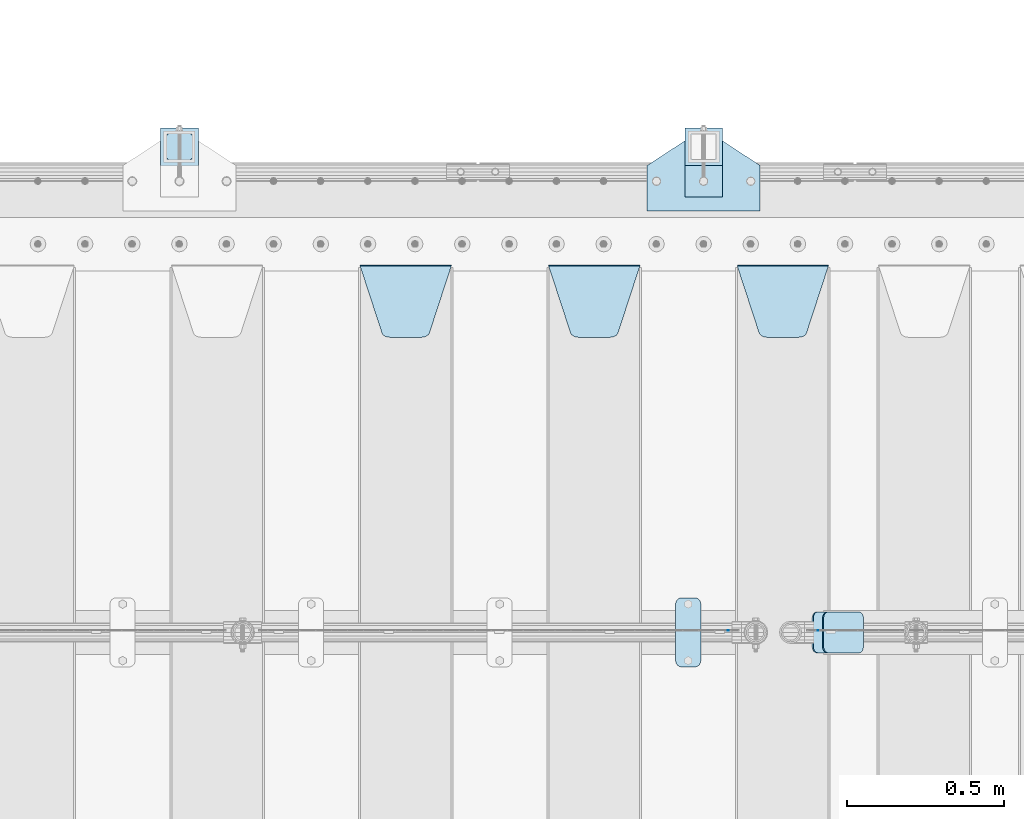
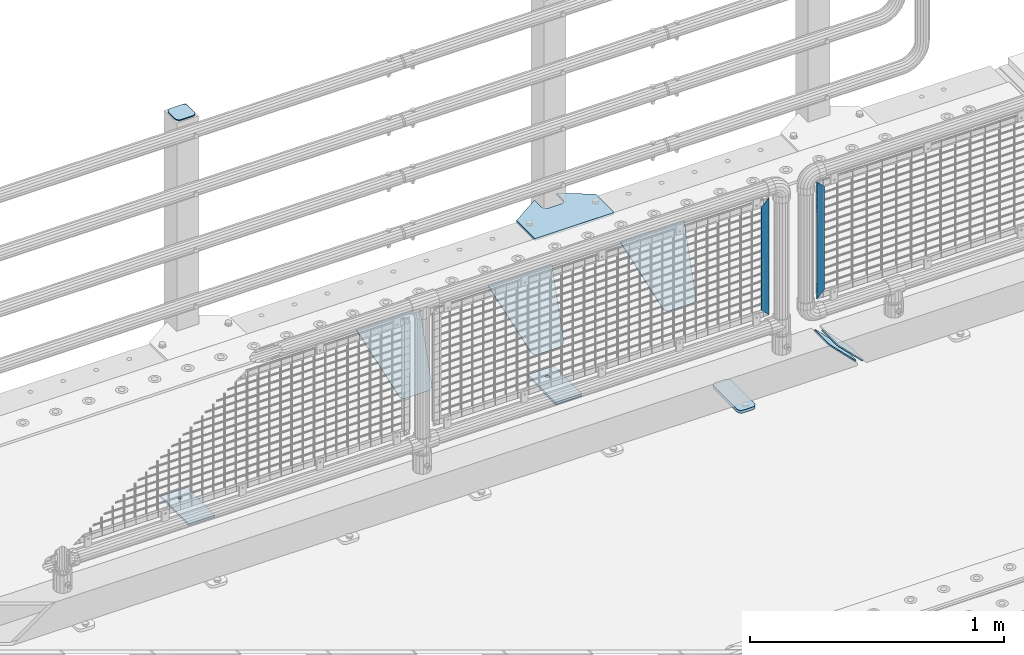
# One storey, part 250 of 270: 13 plates.
"""IFC2X3 building model written with IfcOpenShell, lengths in millimetres."""

import ifcopenshell
import ifcopenshell.guid

model = None  # the IFC model being written
_history = None  # IfcOwnerHistory: only IFC2X3 demands one
_inside = {}  # id of a spatial element -> (the spatial element, [elements in it])
_under = {}  # id of a project, library or spatial element -> (it, [spatial elements below it])
_declared = {}  # id of a project -> (the project, [libraries it declares])
_typed = {}  # id of a type object -> (the type object, [elements of that type])
_made_of = {}  # id of a material, layer set ... -> (it, [elements and type objects made of it])


def new_model(schema):
    """Start an empty IFC model of exactly this schema.

    Asked for "IFC4X3", IfcOpenShell would pick the latest addendum, in which some entities
    have other attributes; the version numbers below select the first issue.
    IFC2X3 requires an IfcOwnerHistory on every rooted entity: one is made here for all.
    """
    global model, _history
    if schema == "IFC4X3":
        model = ifcopenshell.file(schema_version=(4, 3, 0, 0))
    else:
        model = ifcopenshell.file(schema=schema)
    _inside.clear()
    _under.clear()
    _declared.clear()
    _typed.clear()
    _made_of.clear()
    _history = None
    if model.schema == "IFC2X3":
        org = make("IfcOrganization", Name="unknown")
        user = make(
            "IfcPersonAndOrganization",
            ThePerson=make("IfcPerson", FamilyName="unknown"),
            TheOrganization=org,
        )
        app = make(
            "IfcApplication",
            ApplicationDeveloper=org,
            Version="unknown",
            ApplicationFullName="unknown",
            ApplicationIdentifier="unknown",
        )
        _history = make(
            "IfcOwnerHistory",
            OwningUser=user,
            OwningApplication=app,
            ChangeAction="ADDED",
            CreationDate=0,
        )
    return model


def make(cls, **values):
    """One entity of the class cls with the attributes given. An attribute that is None is left unset."""
    return model.create_entity(
        cls, **{name: value for name, value in values.items() if value is not None}
    )


def rooted(cls, **values):
    """An entity with a GlobalId (a new one), such as an element, a storey or a relation."""
    return make(cls, GlobalId=ifcopenshell.guid.new(), OwnerHistory=_history, **values)


def si_unit(unit_type, name, prefix=None):
    """IfcSIUnit, for example si_unit("LENGTHUNIT", "METRE", prefix="MILLI")."""
    return make("IfcSIUnit", UnitType=unit_type, Prefix=prefix, Name=name)


def assignment(units):
    """IfcUnitAssignment: the units of a project."""
    return None if units is None else make("IfcUnitAssignment", Units=units)


def point(xyz):
    """IfcCartesianPoint."""
    return None if xyz is None else make("IfcCartesianPoint", Coordinates=xyz)


def direction(xyz):
    """IfcDirection."""
    return None if xyz is None else make("IfcDirection", DirectionRatios=xyz)


def frame(location, z_axis=None, x_axis=None):
    """IfcAxis2Placement3D, a coordinate frame: its origin and axes. An axis left out is left unset."""
    return make(
        "IfcAxis2Placement3D",
        Location=point(location),
        Axis=direction(z_axis),
        RefDirection=direction(x_axis),
    )


def origin_with_axes():
    """The frame at (0, 0, 0) with the z axis (0, 0, 1) and the x axis (1, 0, 0) written out."""
    return frame((0.0, 0.0, 0.0), z_axis=(0.0, 0.0, 1.0), x_axis=(1.0, 0.0, 0.0))


def place(relative_to, where):
    """IfcLocalPlacement: puts the frame where relative to a parent placement (None: the world)."""
    return make(
        "IfcLocalPlacement", PlacementRelTo=relative_to, RelativePlacement=where
    )


def context(
    kind, dimensions, precision=None, world=None, true_north=None, identifier=None
):
    """IfcGeometricRepresentationContext, for example the 3D "Model" context."""
    return make(
        "IfcGeometricRepresentationContext",
        ContextIdentifier=identifier,
        ContextType=kind,
        CoordinateSpaceDimension=dimensions,
        Precision=precision,
        WorldCoordinateSystem=world,
        TrueNorth=true_north,
    )


def subcontext(parent, identifier, kind, view, scale=None):
    """IfcGeometricRepresentationSubContext, for example "Body" below "Model"."""
    return make(
        "IfcGeometricRepresentationSubContext",
        ContextIdentifier=identifier,
        ContextType=kind,
        ParentContext=parent,
        TargetScale=scale,
        TargetView=view,
    )


def project(units=None, contexts=None):
    """IfcProject with its units and contexts."""
    return rooted(
        "IfcProject",
        Name="project",
        RepresentationContexts=contexts,
        UnitsInContext=assignment(units),
    )


def spatial(cls, under=None, at=None, **own):
    """A site, building, storey or space (cls), placed at a placement, below another one or the project."""
    s = rooted(cls, ObjectPlacement=at, **own)
    if under is not None:
        _under.setdefault(under.id(), (under, []))[1].append(s)
    return s


def faces_of(points, faces, orient=None, outer=None):
    """IfcFace entities. A face is a list of loops; a loop is a list of indices into points, from 0.

    orient and outer hold one flag for each loop. By default every Orientation is true, the
    first loop of a face is its IfcFaceOuterBound and the others are IfcFaceBound.
    """
    made = []
    for i, loops in enumerate(faces):
        bounds = []
        for j, loop in enumerate(loops):
            is_outer = j == 0 if outer is None else outer[i][j]
            bounds.append(
                make(
                    "IfcFaceOuterBound" if is_outer else "IfcFaceBound",
                    Bound=make("IfcPolyLoop", Polygon=[points[k] for k in loop]),
                    Orientation=True if orient is None else orient[i][j],
                )
            )
        made.append(make("IfcFace", Bounds=bounds))
    return made


def faceted_brep(points, faces, orient=None, outer=None, voids=None):
    """IfcFacetedBrep: a solid bounded by flat faces; with voids (closed shells), ...WithVoids."""
    shared = [point(p) for p in points]
    hull = make("IfcClosedShell", CfsFaces=faces_of(shared, faces, orient, outer))
    if voids is None:
        return make("IfcFacetedBrep", Outer=hull)
    return make(
        "IfcFacetedBrepWithVoids",
        Outer=hull,
        Voids=[
            make(cls, CfsFaces=faces_of(shared, fs, o, b)) for cls, fs, o, b in voids
        ],
    )


def shape(context_of_items, identifier, shape_type, items):
    """IfcShapeRepresentation: the items that make up one representation, for example the "Body"."""
    return make(
        "IfcShapeRepresentation",
        ContextOfItems=context_of_items,
        RepresentationIdentifier=identifier,
        RepresentationType=shape_type,
        Items=items,
    )


def material(Name=None, Category=None):
    """IfcMaterial."""
    return make("IfcMaterial", Name=Name, Category=Category)


def made_of(thing, what):
    """Note that an element or type object is made of a material, layer set ...; save() writes the relation."""
    if what is not None:
        _made_of.setdefault(what.id(), (what, []))[1].append(thing)
    return thing


def type_object(cls, material=None, **own):
    """A type object (cls), such as IfcWallType, which elements share."""
    return made_of(rooted(cls, **own), material)


def element(
    cls,
    number,
    at=None,
    inside=None,
    cuts=None,
    type_object=None,
    material=None,
    context=None,
    identifier="Body",
    shape_type=None,
    held_by="IfcProductDefinitionShape",
    body=None,
    shapes=None,
    **own,
):
    """One element of the class cls, such as IfcWall. Its Tag is "e" and its number.

    at: its placement. inside: the storey or other place that contains it. cuts: it is an
    opening in that element (IfcRelVoidsElement). A single representation is given by context,
    identifier, shape_type and body (its items); several are given by shapes. held_by: the class
    of the entity that holds the representations. save() writes the other relations.
    """
    e = rooted(cls, Tag="e%d" % number, ObjectPlacement=at, **own)
    if body is not None:
        shapes = [shape(context, identifier, shape_type, body)]
    if shapes is not None:
        e.Representation = make(held_by, Representations=shapes)
    if inside is not None:
        _inside.setdefault(inside.id(), (inside, []))[1].append(e)
    if cuts is not None:
        rooted(
            "IfcRelVoidsElement", RelatingBuildingElement=cuts, RelatedOpeningElement=e
        )
    if type_object is not None:
        _typed.setdefault(type_object.id(), (type_object, []))[1].append(e)
    return made_of(e, material)


def aggregate(whole, parts):
    """IfcRelAggregates: a whole, such as a stair, and the parts it consists of."""
    return rooted("IfcRelAggregates", RelatingObject=whole, RelatedObjects=parts)


def save(model, path):
    """Write the relations noted so far, then the file.

    IfcRelAggregates (storeys below a building ...), IfcRelContainedInSpatialStructure (elements
    in a storey), IfcRelDefinesByType, IfcRelAssociatesMaterial and IfcRelDeclares: one each for
    every whole, place, type object, material and project.
    """
    for whole, parts in _under.values():
        aggregate(whole, parts)
    for where, things in _inside.values():
        rooted(
            "IfcRelContainedInSpatialStructure",
            RelatedElements=things,
            RelatingStructure=where,
        )
    for kind, things in _typed.values():
        rooted("IfcRelDefinesByType", RelatedObjects=things, RelatingType=kind)
    for what, things in _made_of.values():
        rooted("IfcRelAssociatesMaterial", RelatedObjects=things, RelatingMaterial=what)
    for by, libraries in _declared.values():
        rooted("IfcRelDeclares", RelatingContext=by, RelatedDefinitions=libraries)
    model.write(path)


model = new_model("IFC2X3")

# Units and contexts
model_context = context("Model", 3, precision=1e-05, world=origin_with_axes())
body_context = subcontext(model_context, "Body", "Model", "MODEL_VIEW")
ifc_project = project(units=[si_unit("LENGTHUNIT", "METRE", prefix="MILLI"), si_unit("AREAUNIT", "SQUARE_METRE"), si_unit("VOLUMEUNIT", "CUBIC_METRE"), si_unit("MASSUNIT", "GRAM", prefix="KILO"), si_unit("TIMEUNIT", "SECOND"), si_unit("PLANEANGLEUNIT", "RADIAN"), si_unit("SOLIDANGLEUNIT", "STERADIAN"), si_unit("THERMODYNAMICTEMPERATUREUNIT", "DEGREE_CELSIUS"), si_unit("LUMINOUSINTENSITYUNIT", "LUMEN")], contexts=[model_context])

# Site, building, storey
site_placement = place(None, origin_with_axes())
site = spatial("IfcSite", under=ifc_project, at=site_placement, CompositionType="ELEMENT")
building_placement = place(site_placement, origin_with_axes())
building = spatial("IfcBuilding", under=site, at=building_placement, Name="Standard", CompositionType="ELEMENT")
storey_placement = place(building_placement, origin_with_axes())
storey = spatial("IfcBuildingStorey", under=building, at=storey_placement, Name="Undefined", CompositionType="ELEMENT", Elevation=0.0)

# Plates
ifc_material_1 = material(Name="STEEL/S355J2")
plate_type_1 = type_object("IfcPlateType", PredefinedType="NOTDEFINED")
plate_1_placement = place(storey_placement, frame((18238.0, -14995.0, 5.00000000004911), z_axis=(0.0, 1.0, 0.0), x_axis=(1.0, 0.0, 0.0)))
element("IfcPlate", 1, at=plate_1_placement, inside=storey, type_object=plate_type_1, material=ifc_material_1, context=body_context, shape_type="Brep", body=[
    faceted_brep([(0.0, -5.0, 0.0), (2.31396552408114e-06, -5.0, 145.0), (2.31396552408114e-06, 5.0, 145.0), (0.0, 5.0, 0.0), (130.0, -5.0, 230.0), (130.0, 5.0, 230.0), (130.0, -5.0, 180.0), (130.0, 5.0, 180.0), (130.48036798992, -5.0, 175.122741949597), (130.48036798992, 5.0, 175.122741949597), (131.903011687216, -5.0, 170.432914190873), (131.903011687216, 5.0, 170.432914190873), (134.213259692435, -5.0, 166.11074417451), (134.213259692435, 5.0, 166.11074417451), (137.322330470335, -5.0, 162.322330470337), (137.322330470335, 5.0, 162.322330470337), (141.110744174512, -5.0, 159.213259692437), (141.110744174512, 5.0, 159.213259692437), (145.432914190871, -5.0, 156.903011687218), (145.432914190871, 5.0, 156.903011687218), (150.122741949595, -5.0, 155.48036798992), (150.122741949595, 5.0, 155.48036798992), (155.0, -5.0, 155.0), (155.0, 5.0, 155.0), (205.0, -5.0, 155.0), (205.0, 5.0, 155.0), (209.877258050405, -5.0, 155.48036798992), (209.877258050405, 5.0, 155.48036798992), (214.567085809129, -5.0, 156.903011687218), (214.567085809129, 5.0, 156.903011687218), (218.889255825488, -5.0, 159.213259692437), (218.889255825488, 5.0, 159.213259692437), (222.677669529665, -5.0, 162.322330470337), (222.677669529665, 5.0, 162.322330470337), (225.786740307565, -5.0, 166.11074417451), (225.786740307565, 5.0, 166.11074417451), (228.096988312784, -5.0, 170.432914190873), (228.096988312784, 5.0, 170.432914190873), (229.51963201008, -5.0, 175.122741949597), (229.51963201008, 5.0, 175.122741949597), (230.0, -5.0, 180.0), (230.0, 5.0, 180.0), (230.0, -5.0, 230.0), (230.0, 5.0, 230.0), (360.0, -5.0, 145.0), (360.0, 5.0, 145.0), (360.0, -5.0, -7.27595761418343e-12), (360.0, 5.0, -7.27595761418343e-12)], [[[0, 1, 2, 3]], [[1, 4, 5, 2]], [[4, 6, 7, 5]], [[6, 8, 9, 7]], [[8, 10, 11, 9]], [[10, 12, 13, 11]], [[12, 14, 15, 13]], [[14, 16, 17, 15]], [[16, 18, 19, 17]], [[18, 20, 21, 19]], [[20, 22, 23, 21]], [[22, 24, 25, 23]], [[24, 26, 27, 25]], [[26, 28, 29, 27]], [[28, 30, 31, 29]], [[30, 32, 33, 31]], [[32, 34, 35, 33]], [[34, 36, 37, 35]], [[36, 38, 39, 37]], [[38, 40, 41, 39]], [[40, 42, 43, 41]], [[42, 44, 45, 43]], [[44, 46, 47, 45]], [[46, 0, 3, 47]], [[5, 7, 9, 11, 13, 15, 17, 19, 21, 23, 25, 27, 29, 31, 33, 35, 37, 39, 41, 43, 45, 47, 3, 2]], [[46, 44, 42, 40, 38, 36, 34, 32, 30, 28, 26, 24, 22, 20, 18, 16, 14, 12, 10, 8, 6, 4, 1, 0]]]),
])
plate_type_2 = type_object("IfcPlateType", PredefinedType="NOTDEFINED")
for number, where, z_axis, x_axis in (
    (2, (18358.0000000001, -14949.9999999998, -850.000000000002), (0.0, 1.0, 0.0), (1.0, 0.0, 0.0)),
    (3, (16690.0000000001, -14949.9999999998, -850.000000000002), (0.0, 1.0, 0.0), (1.0, 0.0, 0.0)),
):
    element("IfcPlate", number, at=place(storey_placement, frame(where, z_axis=z_axis, x_axis=x_axis)), inside=storey, type_object=plate_type_2, material=ifc_material_1, context=body_context, shape_type="Brep", body=[
        faceted_brep([(66.3639610305399, -5.0, 163.636038969114), (66.3639610305399, 5.0, 163.636038969114), (59.9999999998618, 5.0, 160.999999999793), (59.9999999998618, -5.0, 160.999999999793), (53.6360389691836, 5.0, 163.636038969114), (53.6360389691836, -5.0, 163.636038969114), (50.9999999998618, 5.0, 169.999999999793), (50.9999999998618, -5.0, 169.999999999793), (53.6360389691836, 5.0, 176.363961030471), (53.6360389691836, -5.0, 176.363961030471), (59.9999999998618, 5.0, 178.999999999793), (59.9999999998618, -5.0, 178.999999999793), (66.3639610305399, 5.0, 176.363961030471), (66.3639610305399, -5.0, 176.363961030471), (68.9999999998618, 5.0, 169.999999999793), (68.9999999998618, -5.0, 169.999999999793), (120.0, -5.0, 0.0), (120.0, -5.0, 220.0), (0.0, -5.0, 220.0), (0.0, -5.0, 0.0), (0.0, 5.0, 0.0), (120.0, 5.0, 0.0), (120.0, 5.0, 220.0), (0.0, 5.0, 220.0)], [[[0, 1, 2, 3]], [[3, 2, 4, 5]], [[5, 4, 6, 7]], [[7, 6, 8, 9]], [[9, 8, 10, 11]], [[11, 10, 12, 13]], [[13, 12, 14, 15]], [[15, 14, 1, 0]], [[16, 17, 18, 19], [3, 5, 7, 9, 11, 13, 15, 0]], [[16, 19, 20, 21]], [[17, 16, 21, 22]], [[18, 17, 22, 23]], [[19, 18, 23, 20]], [[22, 21, 20, 23], [10, 8, 6, 4, 2, 1, 14, 12]]]),
    ])
plate_type_3 = type_object("IfcPlateType", PredefinedType="NOTDEFINED")
plate_2_placement = place(storey_placement, frame((16794.0000000001, -14833.9999999998, 1012.50000000001), z_axis=(0.0, 1.0, 0.0), x_axis=(-1.0, 0.0, 0.0)))
element("IfcPlate", 4, at=plate_2_placement, inside=storey, type_object=plate_type_3, material=ifc_material_1, context=body_context, shape_type="Brep", body=[
    faceted_brep([(0.0, -2.5, 19.0), (0.0, -2.5, 69.0), (0.0, 2.5, 69.0), (0.0, 2.5, 19.0), (0.476369668544066, -2.5, 73.2278977451697), (0.476369668544066, 2.5, 73.2278977451697), (1.88159150985302, -2.5, 77.2437910432327), (1.88159150985302, 2.5, 77.2437910432327), (4.14520183310742, -2.5, 80.8463062353167), (4.14520183310742, 2.5, 80.8463062353167), (7.15369376468516, -2.5, 83.8547981668926), (7.15369376468516, 2.5, 83.8547981668926), (10.7562089567655, -2.5, 86.1184084901452), (10.7562089567655, 2.5, 86.1184084901452), (14.7721022548285, -2.5, 87.5236303314541), (14.7721022548285, 2.5, 87.5236303314541), (19.0, -2.5, 88.0), (19.0, 2.5, 88.0), (69.0, -2.5, 88.0), (69.0, 2.5, 88.0), (73.2278977451715, -2.5, 87.5236303314541), (73.2278977451715, 2.5, 87.5236303314541), (77.2437910432345, -2.5, 86.1184084901452), (77.2437910432345, 2.5, 86.1184084901452), (80.8463062353148, -2.5, 83.8547981668926), (80.8463062353148, 2.5, 83.8547981668926), (83.8547981668926, -2.5, 80.8463062353167), (83.8547981668926, 2.5, 80.8463062353167), (86.118408490147, -2.5, 77.2437910432345), (86.118408490147, 2.5, 77.2437910432345), (87.5236303314559, -2.5, 73.2278977451697), (87.5236303314559, 2.5, 73.2278977451697), (88.0, -2.5, 69.0), (88.0, 2.5, 69.0), (88.0, -2.5, 19.0), (88.0, 2.5, 19.0), (87.5236303314559, -2.5, 14.7721022548303), (87.5236303314559, 2.5, 14.7721022548303), (86.118408490147, -2.5, 10.7562089567673), (86.118408490147, 2.5, 10.7562089567673), (83.8547981668926, -2.5, 7.15369376468334), (83.8547981668926, 2.5, 7.15369376468334), (80.8463062353148, -2.5, 4.14520183310742), (80.8463062353148, 2.5, 4.14520183310742), (77.2437910432345, -2.5, 1.88159150985484), (77.2437910432345, 2.5, 1.88159150985484), (73.2278977451715, -2.5, 0.476369668545885), (73.2278977451715, 2.5, 0.476369668545885), (69.0, -2.5, 0.0), (69.0, 2.5, 0.0), (19.0, -2.5, 0.0), (19.0, 2.5, 0.0), (14.7721022548285, -2.5, 0.476369668545885), (14.7721022548285, 2.5, 0.476369668545885), (10.7562089567655, -2.5, 1.88159150985484), (10.7562089567655, 2.5, 1.88159150985484), (7.15369376468516, -2.5, 4.14520183310742), (7.15369376468516, 2.5, 4.14520183310742), (4.14520183310742, -2.5, 7.15369376468334), (4.14520183310742, 2.5, 7.15369376468334), (1.88159150985302, -2.5, 10.7562089567673), (1.88159150985302, 2.5, 10.7562089567673), (0.476369668544066, -2.5, 14.7721022548303), (0.476369668544066, 2.5, 14.7721022548303)], [[[0, 1, 2, 3]], [[1, 4, 5, 2]], [[4, 6, 7, 5]], [[6, 8, 9, 7]], [[8, 10, 11, 9]], [[10, 12, 13, 11]], [[12, 14, 15, 13]], [[14, 16, 17, 15]], [[16, 18, 19, 17]], [[18, 20, 21, 19]], [[20, 22, 23, 21]], [[22, 24, 25, 23]], [[24, 26, 27, 25]], [[26, 28, 29, 27]], [[28, 30, 31, 29]], [[30, 32, 33, 31]], [[32, 34, 35, 33]], [[34, 36, 37, 35]], [[36, 38, 39, 37]], [[38, 40, 41, 39]], [[40, 42, 43, 41]], [[42, 44, 45, 43]], [[44, 46, 47, 45]], [[46, 48, 49, 47]], [[48, 50, 51, 49]], [[50, 52, 53, 51]], [[52, 54, 55, 53]], [[54, 56, 57, 55]], [[56, 58, 59, 57]], [[58, 60, 61, 59]], [[60, 62, 63, 61]], [[62, 0, 3, 63]], [[5, 7, 9, 11, 13, 15, 17, 19, 21, 23, 25, 27, 29, 31, 33, 35, 37, 39, 41, 43, 45, 47, 49, 51, 53, 55, 57, 59, 61, 63, 3, 2]], [[62, 60, 58, 56, 54, 52, 50, 48, 46, 44, 42, 40, 38, 36, 34, 32, 30, 28, 26, 24, 22, 20, 18, 16, 14, 12, 10, 8, 6, 4, 1, 0]]]),
])
plate_type_4 = type_object("IfcPlateType", PredefinedType="NOTDEFINED")
plate_3_placement = place(storey_placement, frame((18358.0000000001, -14949.9999999998, -857.500000000002), z_axis=(0.0, 1.0, 0.0), x_axis=(1.0, 0.0, 0.0)))
element("IfcPlate", 5, at=plate_3_placement, inside=storey, type_object=plate_type_4, material=ifc_material_1, context=body_context, shape_type="Brep", body=[
    faceted_brep([(0.0, -2.5, 0.0), (0.0, -2.5, 100.0), (0.0, 2.5, 100.0), (0.0, 2.5, 0.0), (120.0, -2.5, 100.0), (120.0, 2.5, 100.0), (120.0, -2.5, 0.0), (120.0, 2.5, 0.0)], [[[0, 1, 2, 3]], [[1, 4, 5, 2]], [[4, 6, 7, 5]], [[6, 0, 3, 7]], [[5, 7, 3, 2]], [[6, 4, 1, 0]]]),
])
plate_type_5 = type_object("IfcPlateType", PredefinedType="NOTDEFINED")
plate_4_placement = place(storey_placement, frame((18329.0, -16225.5, 21.0199999999977), z_axis=(1.0, 0.0, 0.0), x_axis=(0.0, -1.0, 0.0)))
element("IfcPlate", 6, at=plate_4_placement, inside=storey, type_object=plate_type_5, material=ifc_material_1, context=body_context, shape_type="Brep", body=[
    faceted_brep([(0.0, -7.0, 20.0), (0.0, -7.0, 60.0), (0.0, 7.0, 60.0), (0.0, 7.0, 20.0), (0.384294391937146, -7.0, 63.9018064403208), (0.384294391937146, 7.0, 63.9018064403208), (1.52240934977453, -7.0, 67.6536686473009), (1.52240934977453, 7.0, 67.6536686473009), (3.37060775395003, -7.0, 71.1114046603907), (3.37060775395003, 7.0, 71.1114046603907), (5.8578643762703, -7.0, 74.1421356237297), (5.8578643762703, 7.0, 74.1421356237297), (8.88859533960931, -7.0, 76.62939224605), (8.88859533960931, 7.0, 76.62939224605), (12.3463313526991, -7.0, 78.4775906502255), (12.3463313526991, 7.0, 78.4775906502255), (16.0981935596792, -7.0, 79.6157056080629), (16.0981935596792, 7.0, 79.6157056080629), (20.0, -7.0, 80.0), (20.0, 7.0, 80.0), (200.0, -7.0, 80.0), (200.0, 7.0, 80.0), (203.901806440321, -7.0, 79.6157056080629), (203.901806440321, 7.0, 79.6157056080629), (207.653668647301, -7.0, 78.4775906502255), (207.653668647301, 7.0, 78.4775906502255), (211.111404660391, -7.0, 76.62939224605), (211.111404660391, 7.0, 76.62939224605), (214.142135623733, -7.0, 74.1421356237297), (214.142135623733, 7.0, 74.1421356237297), (216.629392246054, -7.0, 71.1114046603907), (216.629392246054, 7.0, 71.1114046603907), (218.477590650225, -7.0, 67.6536686473009), (218.477590650225, 7.0, 67.6536686473009), (219.615705608063, -7.0, 63.9018064403208), (219.615705608063, 7.0, 63.9018064403208), (220.0, -7.0, 60.0), (220.0, 7.0, 60.0), (220.0, -7.0, 20.0), (220.0, 7.0, 20.0), (219.615705608063, -7.0, 16.0981935596792), (219.615705608063, 7.0, 16.0981935596792), (218.477590650225, -7.0, 12.3463313526991), (218.477590650225, 7.0, 12.3463313526991), (216.629392246054, -7.0, 8.88859533960931), (216.629392246054, 7.0, 8.88859533960931), (214.142135623733, -7.0, 5.8578643762703), (214.142135623733, 7.0, 5.8578643762703), (211.111404660391, -7.0, 3.37060775395003), (211.111404660391, 7.0, 3.37060775395003), (207.653668647301, -7.0, 1.52240934977453), (207.653668647301, 7.0, 1.52240934977453), (203.901806440321, -7.0, 0.384294391937146), (203.901806440321, 7.0, 0.384294391937146), (200.0, -7.0, 0.0), (200.0, 7.0, 0.0), (20.0, -7.0, 0.0), (20.0, 7.0, 0.0), (16.0981935596792, -7.0, 0.384294391937146), (16.0981935596792, 7.0, 0.384294391937146), (12.3463313526991, -7.0, 1.52240934977453), (12.3463313526991, 7.0, 1.52240934977453), (8.88859533960931, -7.0, 3.37060775395003), (8.88859533960931, 7.0, 3.37060775395003), (5.8578643762703, -7.0, 5.8578643762703), (5.8578643762703, 7.0, 5.8578643762703), (3.37060775395003, -7.0, 8.88859533960931), (3.37060775395003, 7.0, 8.88859533960931), (1.52240934977453, -7.0, 12.3463313526991), (1.52240934977453, 7.0, 12.3463313526991), (0.384294391937146, -7.0, 16.0981935596792), (0.384294391937146, 7.0, 16.0981935596792)], [[[0, 1, 2, 3]], [[1, 4, 5, 2]], [[4, 6, 7, 5]], [[6, 8, 9, 7]], [[8, 10, 11, 9]], [[10, 12, 13, 11]], [[12, 14, 15, 13]], [[14, 16, 17, 15]], [[16, 18, 19, 17]], [[18, 20, 21, 19]], [[20, 22, 23, 21]], [[22, 24, 25, 23]], [[24, 26, 27, 25]], [[26, 28, 29, 27]], [[28, 30, 31, 29]], [[30, 32, 33, 31]], [[32, 34, 35, 33]], [[34, 36, 37, 35]], [[36, 38, 39, 37]], [[38, 40, 41, 39]], [[40, 42, 43, 41]], [[42, 44, 45, 43]], [[44, 46, 47, 45]], [[46, 48, 49, 47]], [[48, 50, 51, 49]], [[50, 52, 53, 51]], [[52, 54, 55, 53]], [[54, 56, 57, 55]], [[56, 58, 59, 57]], [[58, 60, 61, 59]], [[60, 62, 63, 61]], [[62, 64, 65, 63]], [[64, 66, 67, 65]], [[66, 68, 69, 67]], [[68, 70, 71, 69]], [[70, 0, 3, 71]], [[5, 7, 9, 11, 13, 15, 17, 19, 21, 23, 25, 27, 29, 31, 33, 35, 37, 39, 41, 43, 45, 47, 49, 51, 53, 55, 57, 59, 61, 63, 65, 67, 69, 71, 3, 2]], [[70, 68, 66, 64, 62, 60, 58, 56, 54, 52, 50, 48, 46, 44, 42, 40, 38, 36, 34, 32, 30, 28, 26, 24, 22, 20, 18, 16, 14, 12, 10, 8, 6, 4, 1, 0]]]),
])
ifc_material_2 = material(Name="STEEL/S355N")
plate_type_6 = type_object("IfcPlateType", PredefinedType="NOTDEFINED")
plate_5_placement = place(storey_placement, frame((18525.0, -15168.2322330441, -1.76776695296576), z_axis=(0.0, -0.707106781186548, -0.707106781186547), x_axis=(1.0, 0.0, 0.0)))
element("IfcPlate", 7, at=plate_5_placement, inside=storey, type_object=plate_type_6, material=ifc_material_2, context=body_context, shape_type="Brep", body=[
    faceted_brep([(0.0, -2.5, 0.0), (69.345504679477, -2.5, 300.171731424831), (69.345504679477, 2.5, 300.171731424831), (0.0, 2.5, 0.0), (70.9274061199576, -2.5, 304.8974424154), (70.9274061199576, 2.5, 304.8974424154), (73.3818627772307, -2.49999999999818, 309.234538108527), (73.3818627772307, 2.50000000000182, 309.234538108527), (76.6187032999551, -2.5, 313.023683126103), (76.6187032999551, 2.5, 313.023683126103), (80.5190132704993, -2.5, 316.125672595372), (80.5190132704993, 2.50000000000182, 316.125672595372), (84.9395038596849, -2.49999999999818, 318.426546230476), (84.9395038596849, 2.5, 318.426546230476), (89.7177759439219, -2.49999999999818, 319.841774983275), (89.7177759439219, 2.50000000000182, 319.841774983275), (94.678286292652, -2.5, 320.319366455078), (94.678286292652, 2.5, 320.319366455078), (195.321713707348, -2.5, 320.319366455078), (195.321713707348, 2.5, 320.319366455078), (200.282224056078, -2.49999999999818, 319.841774983275), (200.282224056078, 2.50000000000182, 319.841774983275), (205.060496140315, -2.5, 318.426546230476), (205.060496140315, 2.5, 318.426546230476), (209.480986729501, -2.5, 316.12567259537), (209.480986729501, 2.50000000000182, 316.12567259537), (213.381296700045, -2.5, 313.023683126103), (213.381296700045, 2.5, 313.023683126103), (216.618137222769, -2.49999999999818, 309.234538108525), (216.618137222769, 2.50000000000182, 309.234538108527), (219.072593880042, -2.49999999999818, 304.897442415398), (219.072593880042, 2.50000000000182, 304.897442415397), (220.654495320523, -2.5, 300.171731424831), (220.654495320523, 2.5, 300.171731424831), (290.0, -2.49999999999818, 0.0), (290.0, 2.5, 0.0)], [[[0, 1, 2, 3]], [[1, 4, 5, 2]], [[4, 6, 7, 5]], [[6, 8, 9, 7]], [[8, 10, 11, 9]], [[10, 12, 13, 11]], [[12, 14, 15, 13]], [[14, 16, 17, 15]], [[16, 18, 19, 17]], [[18, 20, 21, 19]], [[20, 22, 23, 21]], [[22, 24, 25, 23]], [[24, 26, 27, 25]], [[26, 28, 29, 27]], [[28, 30, 31, 29]], [[30, 32, 33, 31]], [[32, 34, 35, 33]], [[34, 0, 3, 35]], [[5, 7, 9, 11, 13, 15, 17, 19, 21, 23, 25, 27, 29, 31, 33, 35, 3, 2]], [[34, 32, 30, 28, 26, 24, 22, 20, 18, 16, 14, 12, 10, 8, 6, 4, 1, 0]]]),
])
plate_6_placement = place(storey_placement, frame((17925.0, -15168.2322330441, -1.76776695296576), z_axis=(0.0, -0.707106781186548, -0.707106781186547), x_axis=(1.0, 0.0, 0.0)))
element("IfcPlate", 8, at=plate_6_placement, inside=storey, type_object=plate_type_6, material=ifc_material_2, context=body_context, shape_type="Brep", body=[
    faceted_brep([(0.0, -2.5, 0.0), (69.345504679477, -2.5, 300.171731424831), (69.345504679477, 2.5, 300.171731424831), (0.0, 2.5, 0.0), (70.9274061199576, -2.5, 304.8974424154), (70.9274061199576, 2.5, 304.8974424154), (73.3818627772307, -2.49999999999818, 309.234538108527), (73.3818627772307, 2.50000000000182, 309.234538108527), (76.6187032999551, -2.5, 313.023683126103), (76.6187032999551, 2.5, 313.023683126103), (80.5190132704993, -2.5, 316.125672595372), (80.5190132704993, 2.50000000000182, 316.125672595372), (84.9395038596849, -2.49999999999818, 318.426546230476), (84.9395038596849, 2.5, 318.426546230476), (89.7177759439219, -2.49999999999818, 319.841774983275), (89.7177759439219, 2.50000000000182, 319.841774983275), (94.678286292652, -2.5, 320.319366455078), (94.678286292652, 2.5, 320.319366455078), (195.321713707348, -2.5, 320.319366455078), (195.321713707348, 2.5, 320.319366455078), (200.282224056078, -2.49999999999818, 319.841774983275), (200.282224056078, 2.50000000000182, 319.841774983275), (205.060496140315, -2.5, 318.426546230476), (205.060496140315, 2.5, 318.426546230476), (209.480986729501, -2.5, 316.12567259537), (209.480986729501, 2.50000000000182, 316.12567259537), (213.381296700045, -2.5, 313.023683126103), (213.381296700045, 2.5, 313.023683126103), (216.618137222769, -2.49999999999818, 309.234538108525), (216.618137222769, 2.50000000000182, 309.234538108527), (219.072593880042, -2.49999999999818, 304.897442415398), (219.072593880042, 2.50000000000182, 304.897442415397), (220.654495320523, -2.5, 300.171731424831), (220.654495320523, 2.5, 300.171731424831), (290.0, -2.49999999999818, 0.0), (290.0, 2.5, 0.0)], [[[0, 1, 2, 3]], [[1, 4, 5, 2]], [[4, 6, 7, 5]], [[6, 8, 9, 7]], [[8, 10, 11, 9]], [[10, 12, 13, 11]], [[12, 14, 15, 13]], [[14, 16, 17, 15]], [[16, 18, 19, 17]], [[18, 20, 21, 19]], [[20, 22, 23, 21]], [[22, 24, 25, 23]], [[24, 26, 27, 25]], [[26, 28, 29, 27]], [[28, 30, 31, 29]], [[30, 32, 33, 31]], [[32, 34, 35, 33]], [[34, 0, 3, 35]], [[5, 7, 9, 11, 13, 15, 17, 19, 21, 23, 25, 27, 29, 31, 33, 35, 3, 2]], [[34, 32, 30, 28, 26, 24, 22, 20, 18, 16, 14, 12, 10, 8, 6, 4, 1, 0]]]),
])
plate_7_placement = place(storey_placement, frame((17325.0, -15168.2322330441, -1.76776695296576), z_axis=(0.0, -0.707106781186548, -0.707106781186547), x_axis=(1.0, 0.0, 0.0)))
element("IfcPlate", 9, at=plate_7_placement, inside=storey, type_object=plate_type_6, material=ifc_material_2, context=body_context, shape_type="Brep", body=[
    faceted_brep([(0.0, -2.5, 0.0), (69.345504679477, -2.5, 300.171731424831), (69.345504679477, 2.5, 300.171731424831), (0.0, 2.5, 0.0), (70.9274061199576, -2.5, 304.8974424154), (70.9274061199576, 2.5, 304.8974424154), (73.3818627772307, -2.49999999999818, 309.234538108527), (73.3818627772307, 2.50000000000182, 309.234538108527), (76.6187032999551, -2.5, 313.023683126103), (76.6187032999551, 2.5, 313.023683126103), (80.5190132704993, -2.5, 316.125672595372), (80.5190132704993, 2.50000000000182, 316.125672595372), (84.9395038596849, -2.49999999999818, 318.426546230476), (84.9395038596849, 2.5, 318.426546230476), (89.7177759439219, -2.49999999999818, 319.841774983275), (89.7177759439219, 2.50000000000182, 319.841774983275), (94.678286292652, -2.5, 320.319366455078), (94.678286292652, 2.5, 320.319366455078), (195.321713707348, -2.5, 320.319366455078), (195.321713707348, 2.5, 320.319366455078), (200.282224056078, -2.49999999999818, 319.841774983275), (200.282224056078, 2.50000000000182, 319.841774983275), (205.060496140315, -2.5, 318.426546230476), (205.060496140315, 2.5, 318.426546230476), (209.480986729501, -2.5, 316.12567259537), (209.480986729501, 2.50000000000182, 316.12567259537), (213.381296700045, -2.5, 313.023683126103), (213.381296700045, 2.5, 313.023683126103), (216.618137222769, -2.49999999999818, 309.234538108525), (216.618137222769, 2.50000000000182, 309.234538108527), (219.072593880042, -2.49999999999818, 304.897442415398), (219.072593880042, 2.50000000000182, 304.897442415397), (220.654495320523, -2.5, 300.171731424831), (220.654495320523, 2.5, 300.171731424831), (290.0, -2.49999999999818, 0.0), (290.0, 2.5, 0.0)], [[[0, 1, 2, 3]], [[1, 4, 5, 2]], [[4, 6, 7, 5]], [[6, 8, 9, 7]], [[8, 10, 11, 9]], [[10, 12, 13, 11]], [[12, 14, 15, 13]], [[14, 16, 17, 15]], [[16, 18, 19, 17]], [[18, 20, 21, 19]], [[20, 22, 23, 21]], [[22, 24, 25, 23]], [[24, 26, 27, 25]], [[26, 28, 29, 27]], [[28, 30, 31, 29]], [[30, 32, 33, 31]], [[32, 34, 35, 33]], [[34, 0, 3, 35]], [[5, 7, 9, 11, 13, 15, 17, 19, 21, 23, 25, 27, 29, 31, 33, 35, 3, 2]], [[34, 32, 30, 28, 26, 24, 22, 20, 18, 16, 14, 12, 10, 8, 6, 4, 1, 0]]]),
])
ifc_material_3 = material(Name="Misc_Undefined")
plate_type_7 = type_object("IfcPlateType", PredefinedType="NOTDEFINED")
plate_8_placement = place(storey_placement, frame((18495.4996874836, -16329.5, 879.52), z_axis=(0.707103624179499, 0.0, -0.707109938179501), x_axis=(0.707109938179513, 0.0, 0.707103624179487)))
element("IfcPlate", 10, at=plate_8_placement, inside=storey, type_object=plate_type_7, material=ifc_material_3, context=body_context, shape_type="Brep", body=[
    faceted_brep([(0.0, -1.5, 0.0), (-348.605163574224, -1.5, 348.602081298828), (-348.605163574224, 1.5, 348.602081298828), (0.0, 1.5, 0.0), (-348.605163574226, -1.5, 398.099334716795), (-348.605163574226, 1.5, 398.099334716795), (49.4976959228497, -1.5, -7.27595761418343e-12), (49.4976959228497, 1.5, -7.27595761418343e-12)], [[[0, 1, 2, 3]], [[1, 4, 5, 2]], [[4, 6, 7, 5]], [[6, 0, 3, 7]], [[5, 7, 3, 2]], [[6, 4, 1, 0]]]),
])
plate_9_placement = place(storey_placement, frame((18783.1100258824, -16329.5000354956, 879.520017263589), z_axis=(-0.707106781186548, 0.0, -0.707106781186548), x_axis=(-0.707106781186548, 0.0, 0.707106781186548)))
element("IfcPlate", 11, at=plate_9_placement, inside=storey, type_object=plate_type_7, material=ifc_material_3, context=body_context, shape_type="Brep", body=[
    faceted_brep([(0.0, -1.5, 0.0), (-348.603637695362, -1.50000000000364, 348.603668212891), (-348.603637695362, 1.49999999999818, 348.603668212892), (0.0, 1.5, 0.0), (-348.603637695371, -1.50000000000364, 398.101165771484), (-348.603637695371, 1.49999999999818, 398.101165771486), (49.4974975585974, -1.50000000000364, 2.18278728425503e-11), (49.497497558601, 1.49999999999818, 2.36468622460961e-11)], [[[0, 1, 2, 3]], [[1, 4, 5, 2]], [[4, 6, 7, 5]], [[6, 0, 3, 7]], [[5, 7, 3, 2]], [[6, 4, 1, 0]]]),
])
plate_type_8 = type_object("IfcPlateType", PredefinedType="NOTDEFINED")
plate_10_placement = place(storey_placement, frame((18765.192418479, -16270.5, 166.254400376567), z_axis=(0.707410512925777, 0.0, -0.706802918925841), x_axis=(0.0, -1.0, 0.0)))
element("IfcPlate", 12, at=plate_10_placement, inside=storey, type_object=plate_type_8, material=ifc_material_1, context=body_context, shape_type="Brep", body=[
    faceted_brep([(0.0, -2.50000000000182, 20.0), (0.0, -2.50000000000182, 158.926651000977), (0.0, 2.49999999999818, 158.926651000977), (0.0, 2.49999999999818, 20.0), (0.384294391935327, -2.5, 162.828457441299), (0.384294391935327, 2.49999999999818, 162.828457441301), (1.52240934977453, -2.5, 166.580319648279), (1.52240934977453, 2.49999999999818, 166.580319648278), (3.37060775394821, -2.5, 170.038055661367), (3.37060775394821, 2.49999999999818, 170.038055661369), (5.85786437626848, -2.5, 173.068786624706), (5.85786437626848, 2.49999999999818, 173.068786624708), (8.88859533960749, -2.50000000000182, 175.556043247028), (8.88859533960749, 2.49999999999818, 175.556043247028), (12.3463313526991, -2.50000000000182, 177.404241651202), (12.3463313526991, 2.5, 177.404241651202), (16.0981935596774, -2.50000000000182, 178.542356609043), (16.0981935596774, 2.5, 178.542356609041), (20.0, -2.5, 178.926651000975), (20.0, 2.49999999999818, 178.926651000977), (110.0, -2.5, 178.926651000975), (110.0, 2.49999999999818, 178.926651000977), (113.901806440321, -2.50000000000182, 178.542356609043), (113.901806440321, 2.5, 178.542356609041), (117.653668647301, -2.50000000000182, 177.404241651202), (117.653668647301, 2.5, 177.404241651202), (121.111404660391, -2.50000000000182, 175.556043247028), (121.111404660391, 2.49999999999818, 175.556043247028), (124.14213562373, -2.5, 173.068786624706), (124.14213562373, 2.49999999999818, 173.068786624708), (126.62939224605, -2.5, 170.038055661367), (126.62939224605, 2.49999999999818, 170.038055661369), (128.477590650225, -2.5, 166.580319648279), (128.477590650225, 2.49999999999818, 166.580319648278), (129.615705608063, -2.5, 162.828457441299), (129.615705608063, 2.49999999999818, 162.828457441301), (130.0, -2.50000000000182, 158.926651000977), (130.0, 2.49999999999818, 158.926651000977), (130.0, -2.50000000000182, 20.0), (130.0, 2.49999999999818, 20.0), (129.615705608063, -2.50000000000182, 16.0981935596792), (129.615705608063, 2.49999999999818, 16.0981935596792), (128.477590650225, -2.5, 12.3463313526991), (128.477590650225, 2.49999999999818, 12.3463313526991), (126.62939224605, -2.5, 8.88859533960749), (126.62939224605, 2.49999999999818, 8.88859533960931), (124.14213562373, -2.50000000000182, 5.8578643762703), (124.14213562373, 2.49999999999818, 5.8578643762703), (121.111404660391, -2.50000000000182, 3.37060775394821), (121.111404660391, 2.5, 3.37060775394821), (117.653668647301, -2.50000000000182, 1.52240934977453), (117.653668647301, 2.49999999999818, 1.52240934977635), (113.901806440321, -2.5, 0.384294391935327), (113.901806440321, 2.5, 0.384294391935327), (110.0, -2.50000000000182, 1.81898940354586e-12), (110.0, 2.5, -1.81898940354586e-12), (20.0, -2.50000000000182, 1.81898940354586e-12), (20.0, 2.5, -1.81898940354586e-12), (16.0981935596774, -2.5, 0.384294391935327), (16.0981935596774, 2.5, 0.384294391935327), (12.3463313526991, -2.50000000000182, 1.52240934977453), (12.3463313526991, 2.49999999999818, 1.52240934977635), (8.88859533960749, -2.50000000000182, 3.37060775394821), (8.88859533960749, 2.5, 3.37060775394821), (5.85786437626848, -2.50000000000182, 5.8578643762703), (5.85786437626848, 2.49999999999818, 5.8578643762703), (3.37060775394821, -2.5, 8.88859533960749), (3.37060775394821, 2.49999999999818, 8.88859533960931), (1.52240934977453, -2.5, 12.3463313526991), (1.52240934977453, 2.49999999999818, 12.3463313526991), (0.384294391935327, -2.50000000000182, 16.0981935596792), (0.384294391935327, 2.49999999999818, 16.0981935596792)], [[[0, 1, 2, 3]], [[1, 4, 5, 2]], [[4, 6, 7, 5]], [[6, 8, 9, 7]], [[8, 10, 11, 9]], [[10, 12, 13, 11]], [[12, 14, 15, 13]], [[14, 16, 17, 15]], [[16, 18, 19, 17]], [[18, 20, 21, 19]], [[20, 22, 23, 21]], [[22, 24, 25, 23]], [[24, 26, 27, 25]], [[26, 28, 29, 27]], [[28, 30, 31, 29]], [[30, 32, 33, 31]], [[32, 34, 35, 33]], [[34, 36, 37, 35]], [[36, 38, 39, 37]], [[38, 40, 41, 39]], [[40, 42, 43, 41]], [[42, 44, 45, 43]], [[44, 46, 47, 45]], [[46, 48, 49, 47]], [[48, 50, 51, 49]], [[50, 52, 53, 51]], [[52, 54, 55, 53]], [[54, 56, 57, 55]], [[56, 58, 59, 57]], [[58, 60, 61, 59]], [[60, 62, 63, 61]], [[62, 64, 65, 63]], [[64, 66, 67, 65]], [[66, 68, 69, 67]], [[68, 70, 71, 69]], [[70, 0, 3, 71]], [[5, 7, 9, 11, 13, 15, 17, 19, 21, 23, 25, 27, 29, 31, 33, 35, 37, 39, 41, 43, 45, 47, 49, 51, 53, 55, 57, 59, 61, 63, 65, 67, 69, 71, 3, 2]], [[70, 68, 66, 64, 62, 60, 58, 56, 54, 52, 50, 48, 46, 44, 42, 40, 38, 36, 34, 32, 30, 28, 26, 24, 22, 20, 18, 16, 14, 12, 10, 8, 6, 4, 1, 0]]]),
])
plate_11_placement = place(storey_placement, frame((18798.1214625381, -16270.5, 156.251473717902), z_axis=(0.707410512925777, 0.0, -0.706802918925841), x_axis=(0.0, -1.0, 0.0)))
element("IfcPlate", 13, at=plate_11_placement, inside=storey, type_object=plate_type_8, material=ifc_material_1, context=body_context, shape_type="Brep", body=[
    faceted_brep([(0.0, -2.50000000000182, 20.0), (0.0, -2.50000000000182, 158.926651000977), (0.0, 2.49999999999818, 158.926651000977), (0.0, 2.49999999999818, 20.0), (0.384294391935327, -2.5, 162.828457441299), (0.384294391935327, 2.49999999999818, 162.828457441301), (1.52240934977453, -2.5, 166.580319648279), (1.52240934977453, 2.49999999999818, 166.580319648278), (3.37060775394821, -2.5, 170.038055661367), (3.37060775394821, 2.49999999999818, 170.038055661369), (5.85786437626848, -2.5, 173.068786624706), (5.85786437626848, 2.49999999999818, 173.068786624708), (8.88859533960749, -2.50000000000182, 175.556043247028), (8.88859533960749, 2.49999999999818, 175.556043247028), (12.3463313526991, -2.50000000000182, 177.404241651202), (12.3463313526991, 2.5, 177.404241651202), (16.0981935596774, -2.50000000000182, 178.542356609043), (16.0981935596774, 2.5, 178.542356609041), (20.0, -2.5, 178.926651000975), (20.0, 2.49999999999818, 178.926651000977), (110.0, -2.5, 178.926651000975), (110.0, 2.49999999999818, 178.926651000977), (113.901806440321, -2.50000000000182, 178.542356609043), (113.901806440321, 2.5, 178.542356609041), (117.653668647301, -2.50000000000182, 177.404241651202), (117.653668647301, 2.5, 177.404241651202), (121.111404660391, -2.50000000000182, 175.556043247028), (121.111404660391, 2.49999999999818, 175.556043247028), (124.14213562373, -2.5, 173.068786624706), (124.14213562373, 2.49999999999818, 173.068786624708), (126.62939224605, -2.5, 170.038055661367), (126.62939224605, 2.49999999999818, 170.038055661369), (128.477590650225, -2.5, 166.580319648279), (128.477590650225, 2.49999999999818, 166.580319648278), (129.615705608063, -2.5, 162.828457441299), (129.615705608063, 2.49999999999818, 162.828457441301), (130.0, -2.50000000000182, 158.926651000977), (130.0, 2.49999999999818, 158.926651000977), (130.0, -2.50000000000182, 20.0), (130.0, 2.49999999999818, 20.0), (129.615705608063, -2.50000000000182, 16.0981935596792), (129.615705608063, 2.49999999999818, 16.0981935596792), (128.477590650225, -2.5, 12.3463313526991), (128.477590650225, 2.49999999999818, 12.3463313526991), (126.62939224605, -2.5, 8.88859533960749), (126.62939224605, 2.49999999999818, 8.88859533960931), (124.14213562373, -2.50000000000182, 5.8578643762703), (124.14213562373, 2.49999999999818, 5.8578643762703), (121.111404660391, -2.50000000000182, 3.37060775394821), (121.111404660391, 2.5, 3.37060775394821), (117.653668647301, -2.50000000000182, 1.52240934977453), (117.653668647301, 2.49999999999818, 1.52240934977635), (113.901806440321, -2.5, 0.384294391935327), (113.901806440321, 2.5, 0.384294391935327), (110.0, -2.50000000000182, 1.81898940354586e-12), (110.0, 2.5, -1.81898940354586e-12), (20.0, -2.50000000000182, 1.81898940354586e-12), (20.0, 2.5, -1.81898940354586e-12), (16.0981935596774, -2.5, 0.384294391935327), (16.0981935596774, 2.5, 0.384294391935327), (12.3463313526991, -2.50000000000182, 1.52240934977453), (12.3463313526991, 2.49999999999818, 1.52240934977635), (8.88859533960749, -2.50000000000182, 3.37060775394821), (8.88859533960749, 2.5, 3.37060775394821), (5.85786437626848, -2.50000000000182, 5.8578643762703), (5.85786437626848, 2.49999999999818, 5.8578643762703), (3.37060775394821, -2.5, 8.88859533960749), (3.37060775394821, 2.49999999999818, 8.88859533960931), (1.52240934977453, -2.5, 12.3463313526991), (1.52240934977453, 2.49999999999818, 12.3463313526991), (0.384294391935327, -2.50000000000182, 16.0981935596792), (0.384294391935327, 2.49999999999818, 16.0981935596792)], [[[0, 1, 2, 3]], [[1, 4, 5, 2]], [[4, 6, 7, 5]], [[6, 8, 9, 7]], [[8, 10, 11, 9]], [[10, 12, 13, 11]], [[12, 14, 15, 13]], [[14, 16, 17, 15]], [[16, 18, 19, 17]], [[18, 20, 21, 19]], [[20, 22, 23, 21]], [[22, 24, 25, 23]], [[24, 26, 27, 25]], [[26, 28, 29, 27]], [[28, 30, 31, 29]], [[30, 32, 33, 31]], [[32, 34, 35, 33]], [[34, 36, 37, 35]], [[36, 38, 39, 37]], [[38, 40, 41, 39]], [[40, 42, 43, 41]], [[42, 44, 45, 43]], [[44, 46, 47, 45]], [[46, 48, 49, 47]], [[48, 50, 51, 49]], [[50, 52, 53, 51]], [[52, 54, 55, 53]], [[54, 56, 57, 55]], [[56, 58, 59, 57]], [[58, 60, 61, 59]], [[60, 62, 63, 61]], [[62, 64, 65, 63]], [[64, 66, 67, 65]], [[66, 68, 69, 67]], [[68, 70, 71, 69]], [[70, 0, 3, 71]], [[5, 7, 9, 11, 13, 15, 17, 19, 21, 23, 25, 27, 29, 31, 33, 35, 37, 39, 41, 43, 45, 47, 49, 51, 53, 55, 57, 59, 61, 63, 65, 67, 69, 71, 3, 2]], [[70, 68, 66, 64, 62, 60, 58, 56, 54, 52, 50, 48, 46, 44, 42, 40, 38, 36, 34, 32, 30, 28, 26, 24, 22, 20, 18, 16, 14, 12, 10, 8, 6, 4, 1, 0]]]),
])

save(model, "model.ifc")
